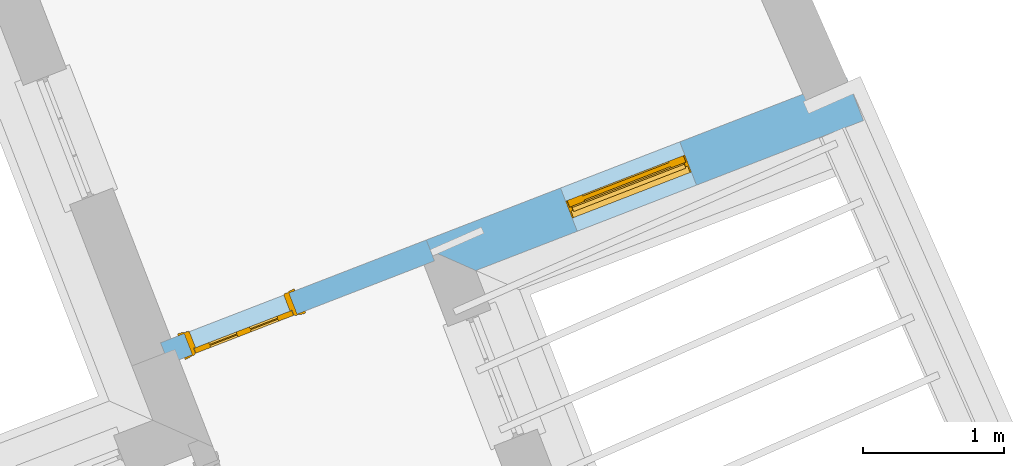
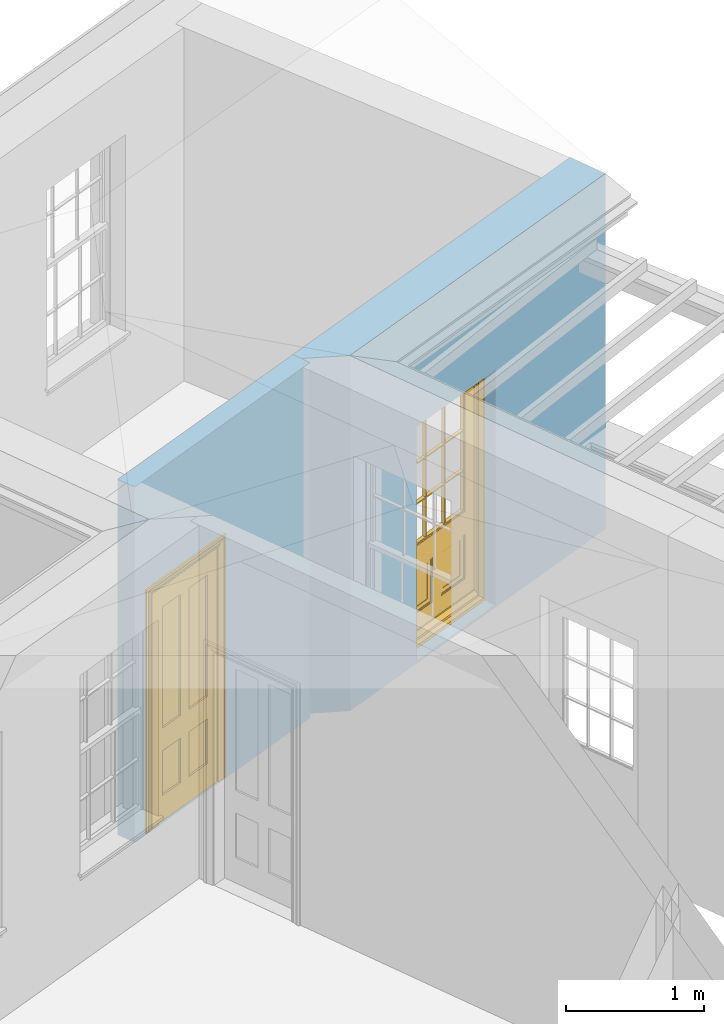
# One storey, part 8 of 11: 2 doors, 2 openings, plus 2 elements that do not belong to this part.
"""IFC2X3 building model written with IfcOpenShell, lengths in metres."""

from ifc_helpers import new_model, si_unit, frame, origin, place, context, subcontext, project, spatial, polyline, outline, extrude, faceted_brep, material, layer, layer_set, layer_usage, element, fill, save


model = new_model("IFC2X3")

# Units and contexts
model_context = context("Model", 3, world=origin())
body_context = subcontext(model_context, "Body", "Model", "MODEL_VIEW")
ifc_project = project(units=[si_unit("PLANEANGLEUNIT", "RADIAN"), si_unit("MASSUNIT", "GRAM", prefix="KILO"), si_unit("FORCEUNIT", "NEWTON", prefix="KILO"), si_unit("LENGTHUNIT", "METRE")], contexts=[model_context])

# Site, building, storey
site_placement = place(None, origin())
site = spatial("IfcSite", under=ifc_project, at=site_placement, CompositionType="ELEMENT")
building_placement = place(None, origin())
building = spatial("IfcBuilding", under=site, at=building_placement, Name="Building plot-5", CompositionType="ELEMENT")
storey_placement = place(None, frame((0.0, 0.0, 7.6)))
storey = spatial("IfcBuildingStorey", under=building, at=storey_placement, Name="Floor 1", CompositionType="ELEMENT", Elevation=7.6)

# Wall, opening, door
ifc_material_1 = material(Name="Masonry")
ifc_layer_1 = layer(ifc_material_1, 0.33, ventilated=False)
ifc_layer_set_1 = layer_set([ifc_layer_1], Name="My Wall")
ifc_layer_usage_1 = layer_usage(ifc_layer_set_1, "AXIS2", "NEGATIVE", 0.08)
wall_1_placement = place(storey_placement, origin())
wall_1 = element("IfcWallStandardCase", 1, at=wall_1_placement, inside=storey, material=ifc_layer_usage_1, Name="exterior", context=body_context, shape_type="SweptSolid", body=[
    extrude(outline(polyline([(61.8338428959176, 59.3683674178337), (62.2606962551514, 59.1796978397062), (65.0186735128031, 60.2469293132381), (64.8995816222499, 60.5546907819187), (61.8338428959176, 59.3683674178337)])), origin(), (0.0, 0.0, 1.0), 3.15),
])
opening_1_placement = place(storey_placement, frame((0.0, 0.0, 0.0199999999999996)))
opening_1 = element("IfcOpeningElement", 2, at=opening_1_placement, cuts=wall_1, Name="Opening", ObjectType="Opening", context=body_context, shape_type="SweptSolid", body=[
    extrude(outline(polyline([(62.9821944736141, 59.4588899921085), (63.8308700387637, 59.7872949024218), (63.7117781482106, 60.0950563711025), (62.8631025830609, 59.7666514607892), (62.9821944736141, 59.4588899921085)])), origin(), (0.0, 0.0, 1.0), 2.08),
])
door_1_placement = place(storey_placement, frame((62.8919733444071, 59.6920426198969, 0.0199999999999996), z_axis=(0.0, 0.0, 1.0), x_axis=(0.848675565149669, 0.328404910313296, 0.0)))
door_1 = element("IfcDoor", 3, at=door_1_placement, inside=storey, Name="bedroom outside door", OverallHeight=2.08, OverallWidth=0.91, context=body_context, shape_type="Brep", held_by="IfcProductRepresentation", body=[
    faceted_brep([(0.545, -0.055, 0.265), (0.745, -0.055, 0.265), (0.745, -0.05, 0.265), (0.545, -0.05, 0.265), (0.745, -0.05, 0.58), (0.545, -0.05, 0.58), (0.545, -0.055, 0.58), (0.515, -0.06, 0.235), (0.775, -0.06, 0.235), (0.745, -0.055, 0.58), (0.515, -0.06, 0.61), (0.515, -0.065, 0.235), (0.775, -0.065, 0.235), (0.775, -0.06, 0.61), (0.515, -0.065, 0.61), (0.785, -0.065, 0.225), (0.505, -0.065, 0.225), (0.775, -0.065, 0.61), (0.505, -0.065, 0.62), (0.785, -0.065, 0.62), (0.505, -0.07, 0.225), (0.785, -0.07, 0.225), (0.505, -0.07, 0.62), (0.785, -0.07, 0.62), (0.883, -0.07, 0.075), (0.898, -0.07, 0.075), (0.405, -0.07, 0.62), (0.405, -0.07, 0.225), (0.027, -0.07, 0.075), (0.785, -0.07, 0.82), (0.125, -0.07, 0.82), (0.405, -0.065, 0.62), (0.405, -0.065, 0.225), (0.898, -0.07, 2.068), (0.027, -0.08, 0.075), (0.883, -0.08, 0.075), (0.125, -0.07, 0.225), (0.012, -0.07, 0.075), (0.785, -0.06, 0.82), (0.125, -0.06, 0.82), (0.125, -0.07, 0.62), (0.125, -0.065, 0.62), (0.395, -0.065, 0.61), (0.395, -0.065, 0.235), (0.125, -0.065, 0.225), (0.785, -0.07, 1.895), (0.027, -0.11, 0.045), (0.883, -0.11, 0.045), (0.558333, -0.06, 0.83), (0.351667, -0.06, 0.83), (0.125, -0.07, 1.895), (0.125, -0.06, 1.895), (0.785, -0.06, 1.895), (0.012, -0.07, 2.068), (0.135, -0.065, 0.61), (0.395, -0.06, 0.61), (0.395, -0.06, 0.235), (0.135, -0.065, 0.235), (0.027, -0.11, 0.027), (0.883, -0.11, 0.027), (0.568333, -0.06, 0.83), (0.558333, -0.03, 0.83), (0.351667, -0.03, 0.83), (0.341667, -0.06, 0.83), (0.135, -0.06, 1.185), (0.135, -0.06, 1.53), (0.775, -0.06, 1.53), (0.775, -0.06, 1.185), (0.135, -0.06, 0.61), (0.365, -0.055, 0.58), (0.365, -0.055, 0.265), (0.135, -0.06, 0.235), (0.568333, -0.06, 1.175), (0.558333, -0.06, 1.175), (0.775, -0.06, 0.83), (0.558333, -0.03, 1.175), (0.785, -0.03, 0.82), (0.125, -0.03, 0.82), (0.351667, -0.03, 1.175), (0.351667, -0.06, 1.175), (0.341667, -0.06, 1.175), (0.135, -0.06, 0.83), (0.135, -0.06, 1.175), (0.135, -0.03, 1.185), (0.135, -0.03, 1.53), (0.135, -0.06, 1.54), (0.351667, -0.06, 1.885), (0.558333, -0.06, 1.885), (0.775, -0.03, 1.53), (0.775, -0.03, 1.185), (0.775, -0.06, 1.175), (0.775, -0.06, 1.54), (0.165, -0.055, 0.58), (0.365, -0.05, 0.58), (0.365, -0.05, 0.265), (0.165, -0.055, 0.265), (0.568333, -0.03, 0.83), (0.568333, -0.03, 1.175), (0.568333, -0.06, 1.185), (0.558333, -0.06, 1.185), (0.775, -0.03, 0.83), (0.785, -0.02, 0.82), (0.125, -0.02, 0.82), (0.341667, -0.03, 0.83), (0.341667, -0.03, 1.175), (0.351667, -0.06, 1.185), (0.341667, -0.06, 1.185), (0.135, -0.03, 0.83), (0.341667, -0.03, 1.185), (0.125, -0.03, 1.895), (0.341667, -0.03, 1.53), (0.341667, -0.06, 1.53), (0.135, -0.06, 1.885), (0.341667, -0.06, 1.54), (0.341667, -0.06, 1.885), (0.558333, -0.03, 1.885), (0.351667, -0.03, 1.885), (0.568333, -0.06, 1.885), (0.785, -0.03, 1.895), (0.568333, -0.03, 1.185), (0.568333, -0.06, 1.53), (0.568333, -0.03, 1.53), (0.568333, -0.06, 1.54), (0.775, -0.06, 1.885), (0.165, -0.05, 0.58), (0.165, -0.05, 0.265), (0.775, -0.03, 1.175), (0.558333, -0.06, 1.53), (0.351667, -0.03, 1.185), (0.558333, -0.03, 1.185), (0.505, -0.02, 0.62), (0.405, -0.02, 0.62), (0.125, -0.02, 1.895), (0.785, -0.02, 1.895), (0.351667, -0.06, 1.53), (0.135, -0.03, 1.175), (0.135, -0.03, 1.54), (0.341667, -0.03, 1.54), (0.135, -0.03, 1.885), (0.351667, -0.06, 1.54), (0.558333, -0.03, 1.54), (0.558333, -0.06, 1.54), (0.351667, -0.03, 1.54), (0.775, -0.03, 1.54), (0.568333, -0.03, 1.54), (0.775, -0.03, 1.885), (0.558333, -0.03, 1.53), (0.405, -0.02, 0.225), (0.505, -0.02, 0.225), (0.125, -0.02, 0.62), (0.785, -0.02, 0.62), (0.012, -0.02, 2.068), (0.898, -0.02, 2.068), (0.351667, -0.03, 1.53), (0.341667, -0.03, 1.885), (0.568333, -0.03, 1.885), (0.405, -0.025, 0.225), (0.405, -0.025, 0.62), (0.505, -0.025, 0.62), (0.505, -0.025, 0.225), (0.898, -0.02, 0.027), (0.012, -0.02, 0.027), (0.125, -0.025, 0.62), (0.785, -0.025, 0.62), (0.395, -0.025, 0.235), (0.395, -0.025, 0.61), (0.125, -0.02, 0.225), (0.125, -0.025, 0.225), (0.515, -0.025, 0.61), (0.515, -0.025, 0.235), (0.785, -0.02, 0.225), (0.785, -0.025, 0.225), (0.135, -0.025, 0.61), (0.775, -0.025, 0.61), (0.135, -0.025, 0.235), (0.395, -0.03, 0.235), (0.395, -0.03, 0.61), (0.515, -0.03, 0.61), (0.515, -0.03, 0.235), (0.775, -0.025, 0.235), (0.135, -0.03, 0.61), (0.775, -0.03, 0.61), (0.135, -0.03, 0.235), (0.365, -0.035, 0.265), (0.365, -0.035, 0.58), (0.545, -0.035, 0.58), (0.545, -0.035, 0.265), (0.775, -0.03, 0.235), (0.165, -0.035, 0.58), (0.745, -0.035, 0.58), (0.165, -0.035, 0.265), (0.365, -0.04, 0.58), (0.365, -0.04, 0.265), (0.545, -0.04, 0.58), (0.545, -0.04, 0.265), (0.745, -0.035, 0.265), (0.165, -0.04, 0.58), (0.745, -0.04, 0.58), (0.165, -0.04, 0.265), (0.745, -0.04, 0.265), (0.885, -0.072, 0.025), (0.025, -0.072, 0.025), (0.025, -0.1, 0.025), (0.885, -0.1, 0.025), (0.9, -0.02, 0.025), (0.01, -0.02, 0.025), (0.9, -0.072, 0.025), (0.91, -0.02, 0.0), (0.0, -0.02, 0.0), (0.01, -0.072, 0.025), (0.9, -0.072, 2.07), (0.9, -0.02, 2.07), (0.885, -0.072, 2.055), (0.91, -0.02, 2.08), (0.01, -0.02, 2.07), (0.0, -0.02, 2.08), (0.01, -0.072, 2.07), (0.025, -0.072, 2.055), (0.0, -0.15, 2.08), (0.91, -0.15, 2.08), (0.01, -0.15, 2.07), (0.9, -0.15, 2.07), (0.01, -0.1, 2.07), (0.9, -0.1, 2.07), (0.0, -0.15, 0.0), (0.91, -0.15, 0.0), (0.01, -0.15, 0.025), (0.9, -0.15, 0.025), (0.01, -0.1, 0.025), (0.025, -0.1, 2.055), (0.9, -0.1, 0.025), (0.885, -0.1, 2.055), (0.898, -0.07, 0.027), (0.012, -0.07, 0.027), (0.883, -0.07, 0.027), (0.027, -0.07, 0.027)], [[[0, 1, 2, 3]], [[2, 4, 5, 3]], [[0, 3, 5, 6]], [[1, 0, 7, 8]], [[9, 4, 2, 1]], [[9, 6, 5, 4]], [[0, 6, 10, 7]], [[8, 7, 11, 12]], [[8, 13, 9, 1]], [[13, 10, 6, 9]], [[7, 10, 14, 11]], [[15, 12, 11, 16]], [[12, 17, 13, 8]], [[17, 14, 10, 13]], [[18, 16, 11, 14]], [[15, 19, 17, 12]], [[15, 16, 20, 21]], [[14, 17, 19, 18]], [[16, 18, 22, 20]], [[21, 23, 19, 15]], [[24, 25, 21, 20]], [[23, 22, 18, 19]], [[20, 22, 26, 27]], [[23, 21, 25]], [[28, 24, 20, 27]], [[22, 23, 29]], [[29, 30, 26, 22]], [[27, 26, 31, 32]], [[23, 25, 33, 29]], [[34, 35, 24, 28]], [[28, 27, 36, 37]], [[38, 39, 30, 29]], [[26, 30, 40]], [[26, 40, 41, 31]], [[42, 43, 32, 31]], [[32, 44, 36, 27]], [[33, 45, 29]], [[46, 47, 35, 34]], [[36, 40, 37]], [[39, 38, 48, 49]], [[50, 30, 39, 51]], [[29, 45, 52, 38]], [[53, 37, 40, 30]], [[44, 41, 40, 36]], [[31, 41, 54, 42]], [[43, 42, 55, 56]], [[57, 44, 32, 43]], [[50, 45, 33, 53]], [[47, 46, 58, 59]], [[60, 48, 38]], [[49, 48, 61, 62]], [[49, 63, 39]], [[50, 53, 30]], [[51, 39, 64, 65]], [[45, 50, 51, 52]], [[66, 67, 38, 52]], [[57, 54, 41, 44]], [[42, 54, 68, 55]], [[56, 55, 69, 70]], [[56, 71, 57, 43]], [[60, 72, 73, 48]], [[60, 38, 74]], [[48, 73, 75, 61]], [[76, 77, 62, 61]], [[62, 78, 79, 49]], [[49, 79, 80, 63]], [[63, 81, 39]], [[82, 64, 39]], [[65, 64, 83, 84]], [[85, 51, 65]], [[52, 51, 86, 87]], [[88, 89, 67, 66]], [[90, 38, 67]], [[91, 66, 52]], [[71, 68, 54, 57]], [[55, 68, 92, 69]], [[69, 93, 94, 70]], [[70, 95, 71, 56]], [[96, 97, 72, 60]], [[73, 72, 98, 99]], [[74, 38, 90]], [[100, 96, 60, 74]], [[75, 73, 79, 78]], [[61, 75, 97, 96]], [[101, 102, 77, 76]], [[77, 103, 62]], [[96, 76, 61]], [[103, 104, 78, 62]], [[80, 79, 105, 106]], [[63, 80, 104, 103]], [[81, 63, 103, 107]], [[81, 82, 39]], [[106, 64, 82, 80]], [[106, 108, 83, 64]], [[84, 83, 77, 109]], [[110, 111, 65, 84]], [[112, 51, 85]], [[113, 85, 65, 111]], [[114, 86, 51]], [[115, 87, 86, 116]], [[117, 52, 87]], [[118, 76, 89, 88]], [[119, 98, 67, 89]], [[120, 121, 88, 66]], [[67, 98, 72, 90]], [[91, 122, 120, 66]], [[91, 52, 123]], [[95, 92, 68, 71]], [[69, 92, 124, 93]], [[94, 93, 124, 125]], [[94, 125, 95, 70]], [[72, 97, 126, 90]], [[127, 99, 98, 120]], [[99, 105, 79, 73]], [[74, 90, 126, 100]], [[96, 100, 76]], [[128, 129, 75, 78]], [[97, 75, 129, 119]], [[130, 131, 102, 101]], [[109, 77, 102, 132]], [[133, 101, 76, 118]], [[77, 107, 103]], [[78, 104, 108, 128]], [[111, 106, 105, 134]], [[104, 80, 82, 135]], [[107, 135, 82, 81]], [[110, 108, 106, 111]], [[104, 135, 83, 108]], [[83, 135, 77]], [[136, 84, 109]], [[110, 84, 136, 137]], [[114, 51, 112]], [[85, 136, 138, 112]], [[113, 137, 136, 85]], [[111, 134, 139, 113]], [[86, 114, 113, 139]], [[140, 141, 87, 115]], [[139, 142, 116, 86]], [[109, 118, 115, 116]], [[117, 123, 52]], [[117, 87, 141, 122]], [[126, 89, 76]], [[143, 118, 88]], [[120, 98, 119, 121]], [[119, 89, 126, 97]], [[144, 143, 88, 121]], [[144, 122, 91, 143]], [[127, 120, 122, 141]], [[143, 91, 123, 145]], [[124, 92, 95, 125]], [[146, 129, 99, 127]], [[99, 129, 128, 105]], [[100, 126, 76]], [[121, 119, 129, 146]], [[147, 131, 130, 148]], [[131, 149, 102]], [[130, 101, 150]], [[102, 151, 132]], [[118, 109, 132, 133]], [[101, 133, 152]], [[107, 77, 135]], [[153, 128, 108, 110]], [[134, 105, 128, 153]], [[109, 138, 136]], [[153, 110, 137, 142]], [[154, 114, 112, 138]], [[137, 113, 114, 154]], [[141, 139, 134, 127]], [[141, 140, 142, 139]], [[144, 140, 115, 155]], [[142, 137, 154, 116]], [[155, 115, 118]], [[116, 154, 109]], [[117, 155, 145, 123]], [[122, 144, 155, 117]], [[143, 145, 118]], [[121, 146, 140, 144]], [[146, 127, 134, 153]], [[156, 157, 131, 147]], [[148, 130, 158, 159]], [[148, 160, 161, 147]], [[157, 162, 149, 131]], [[161, 151, 102, 149]], [[101, 152, 160, 150]], [[163, 158, 130, 150]], [[151, 152, 133, 132]], [[154, 138, 109]], [[142, 140, 146, 153]], [[145, 155, 118]], [[157, 156, 164, 165]], [[147, 166, 167, 156]], [[168, 169, 159, 158]], [[170, 148, 159, 171]], [[148, 170, 160]], [[166, 147, 161]], [[172, 162, 157, 165]], [[166, 149, 162, 167]], [[166, 161, 149]], [[150, 160, 170]], [[163, 173, 168, 158]], [[171, 163, 150, 170]], [[174, 164, 156, 167]], [[175, 176, 165, 164]], [[169, 168, 177, 178]], [[171, 159, 169, 179]], [[167, 162, 172, 174]], [[176, 180, 172, 165]], [[179, 173, 163, 171]], [[181, 177, 168, 173]], [[164, 174, 182, 175]], [[183, 184, 176, 175]], [[178, 177, 185, 186]], [[179, 169, 178, 187]], [[174, 172, 180, 182]], [[184, 188, 180, 176]], [[187, 181, 173, 179]], [[189, 185, 177, 181]], [[175, 182, 190, 183]], [[191, 184, 183, 192]], [[185, 193, 194, 186]], [[187, 178, 186, 195]], [[182, 180, 188, 190]], [[191, 196, 188, 184]], [[195, 189, 181, 187]], [[197, 193, 185, 189]], [[183, 190, 198, 192]], [[198, 196, 191, 192]], [[194, 193, 197, 199]], [[195, 186, 194, 199]], [[188, 196, 198, 190]], [[197, 189, 195, 199]], [[200, 201, 202, 203]], [[201, 200, 204, 205]], [[206, 204, 200]], [[204, 207, 208, 205]], [[209, 201, 205]], [[210, 211, 204, 206]], [[206, 200, 212, 210]], [[211, 213, 207, 204]], [[214, 205, 208, 215]], [[216, 217, 201, 209]], [[205, 214, 216, 209]], [[216, 214, 211, 210]], [[210, 212, 217, 216]], [[214, 215, 213, 211]], [[218, 219, 213, 215]], [[219, 218, 220, 221]], [[221, 220, 222, 223]], [[215, 208, 224, 218]], [[225, 224, 208, 207]], [[224, 226, 220, 218]], [[224, 225, 227, 226]], [[219, 225, 207, 213]], [[228, 222, 220, 226]], [[219, 221, 227, 225]], [[226, 227, 203, 202]], [[202, 229, 222, 228]], [[228, 226, 202]], [[227, 221, 223, 230]], [[230, 203, 227]], [[217, 229, 202, 201]], [[231, 223, 222, 229]], [[230, 223, 231, 203]], [[231, 229, 217, 212]], [[212, 200, 203, 231]], [[33, 152, 151, 53]], [[25, 160, 152, 33]], [[161, 37, 53, 151]], [[232, 160, 25]], [[161, 233, 37]], [[160, 232, 234]], [[24, 234, 232, 25]], [[233, 161, 235]], [[37, 233, 235, 28]], [[161, 160, 234, 235]], [[35, 47, 234, 24]], [[28, 235, 46, 34]], [[58, 235, 234, 59]], [[59, 234, 47]], [[58, 46, 235]]]),
])
fill(opening_1, door_1)

ifc_material_2 = material(Name="Masonry")
ifc_layer_2 = layer(ifc_material_2, 0.16, ventilated=False)
ifc_layer_set_2 = layer_set([ifc_layer_2], Name="My Wall")
ifc_layer_usage_2 = layer_usage(ifc_layer_set_2, "AXIS2", "NEGATIVE", 0.08)
wall_2_placement = place(storey_placement, origin())
wall_2 = element("IfcWallStandardCase", 4, at=wall_2_placement, inside=storey, material=ifc_layer_usage_2, Name="interior", context=body_context, shape_type="SweptSolid", body=[
    extrude(outline(polyline([(61.9661932595023, 59.2480204973953), (61.9084517368099, 59.3972381791799), (60.0171848108104, 58.6653903792473), (60.0749263335028, 58.5161726974627), (61.9661932595023, 59.2480204973953)])), origin(), (0.0, 0.0, 1.0), 3.15),
])
opening_2_placement = place(storey_placement, frame((0.0, 0.0, 0.0199999999999996)))
opening_2 = element("IfcOpeningElement", 5, at=opening_2_placement, cuts=wall_2, Name="Opening", ObjectType="Opening", context=body_context, shape_type="SweptSolid", body=[
    extrude(outline(polyline([(60.9311431117408, 59.0190572057385), (60.185054702818, 58.7303495922763), (60.2427962255104, 58.5811319104917), (60.9888846344332, 58.8698395239539), (60.9311431117408, 59.0190572057385)])), origin(), (0.0, 0.0, 1.0), 2.1),
])
door_2_placement = place(storey_placement, frame((60.960013873087, 58.9444483648462, 0.0199999999999996), z_axis=(0.0, 0.0, 1.0), x_axis=(-0.746088408922795, -0.288707613462229, 0.0)))
door_2 = element("IfcDoor", 6, at=door_2_placement, inside=storey, Name="bedroom inside door", OverallHeight=2.1, OverallWidth=0.8, context=body_context, shape_type="Brep", held_by="IfcProductRepresentation", body=[
    faceted_brep([(0.773, 0.08, 1.895), (0.66, 0.08, 1.895), (0.66, 0.08, 2.073), (0.773, 0.08, 2.073), (0.773, 0.08, 0.82), (0.66, 0.08, 0.82), (0.45, 0.08, 1.895), (0.45, 0.08, 2.073), (0.773, 0.08, 0.62), (0.66, 0.08, 0.62), (0.66, 0.065, 0.82), (0.66, 0.065, 1.895), (0.45, 0.065, 1.895), (0.35, 0.08, 1.895), (0.35, 0.08, 2.073), (0.773, 0.08, 0.225), (0.66, 0.08, 0.225), (0.45, 0.08, 0.62), (0.45, 0.08, 0.82), (0.45, 0.065, 0.82), (0.35, 0.08, 0.82), (0.14, 0.08, 2.073), (0.14, 0.08, 1.895), (0.773, 0.08, 0.0), (0.66, 0.08, 0.0), (0.66, 0.065, 0.225), (0.66, 0.065, 0.62), (0.45, 0.065, 0.62), (0.35, 0.08, 0.62), (0.35, 0.065, 0.82), (0.35, 0.065, 1.895), (0.14, 0.065, 1.895), (0.027, 0.08, 2.073), (0.027, 0.08, 1.895), (0.773, 0.042, 0.0), (0.66, 0.042, 0.0), (0.45, 0.08, 0.0), (0.45, 0.08, 0.225), (0.45, 0.065, 0.225), (0.35, 0.08, 0.225), (0.14, 0.08, 0.82), (0.14, 0.08, 0.62), (0.14, 0.065, 0.82), (0.027, 0.08, 0.82), (0.773, 0.042, 0.225), (0.66, 0.042, 0.225), (0.45, 0.042, 0.0), (0.35, 0.08, 0.0), (0.35, 0.065, 0.225), (0.35, 0.065, 0.62), (0.14, 0.065, 0.62), (0.027, 0.08, 0.62), (0.773, 0.042, 0.62), (0.66, 0.042, 0.62), (0.45, 0.042, 0.225), (0.35, 0.042, 0.0), (0.14, 0.08, 0.225), (0.14, 0.08, 0.0), (0.14, 0.065, 0.225), (0.027, 0.08, 0.225), (0.773, 0.042, 0.82), (0.66, 0.042, 0.82), (0.66, 0.057, 0.62), (0.66, 0.057, 0.225), (0.45, 0.057, 0.225), (0.35, 0.042, 0.225), (0.14, 0.042, 0.0), (0.027, 0.08, 0.0), (0.773, 0.042, 1.895), (0.66, 0.042, 1.895), (0.45, 0.042, 0.62), (0.45, 0.042, 0.82), (0.45, 0.057, 0.62), (0.35, 0.042, 0.62), (0.14, 0.042, 0.225), (0.027, 0.042, 0.0), (0.773, 0.042, 2.073), (0.66, 0.042, 2.073), (0.66, 0.057, 1.895), (0.66, 0.057, 0.82), (0.45, 0.057, 0.82), (0.35, 0.042, 0.82), (0.35, 0.057, 0.62), (0.35, 0.057, 0.225), (0.14, 0.057, 0.225), (0.027, 0.042, 0.225), (0.45, 0.042, 1.895), (0.45, 0.042, 2.073), (0.45, 0.057, 1.895), (0.35, 0.042, 1.895), (0.14, 0.042, 0.82), (0.14, 0.042, 0.62), (0.14, 0.057, 0.62), (0.027, 0.042, 0.62), (0.35, 0.042, 2.073), (0.35, 0.057, 1.895), (0.35, 0.057, 0.82), (0.14, 0.057, 0.82), (0.027, 0.042, 0.82), (0.14, 0.042, 2.073), (0.14, 0.042, 1.895), (0.14, 0.057, 1.895), (0.027, 0.042, 1.895), (0.027, 0.042, 2.073), (0.02, 0.085, 0.0), (0.005, 0.09, 0.0), (0.005, 0.09, 2.095), (0.02, 0.085, 2.08), (0.02, 0.08, 0.0), (0.0, 0.085, 0.0), (0.0, 0.085, 2.1), (0.795, 0.09, 2.095), (0.78, 0.085, 2.08), (0.02, 0.08, 2.08), (0.0, 0.08, 0.0), (-0.032, 0.095, 0.0), (-0.032, 0.095, 2.132), (0.8, 0.085, 2.1), (0.795, 0.09, 0.0), (0.78, 0.085, 0.0), (0.78, 0.08, 2.08), (0.04, 0.04, 0.0), (0.025, 0.04, 0.0), (0.025, 0.04, 2.075), (0.04, 0.04, 2.06), (-0.04, 0.09, 0.0), (-0.04, 0.09, 2.14), (0.832, 0.095, 2.132), (0.8, 0.085, 0.0), (0.78, 0.08, 0.0), (0.8, 0.08, 0.0), (0.86, 0.08, 0.0), (0.86, 0.08, 2.16), (0.8, 0.08, 2.1), (-0.06, 0.08, 2.16), (0.0, 0.08, 2.1), (-0.06, 0.08, 0.0), (-0.04, 0.095, 0.0), (-0.04, 0.095, 2.14), (0.84, 0.09, 2.14), (0.832, 0.095, 0.0), (0.84, 0.09, 0.0), (0.86, 0.095, 0.0), (0.86, 0.095, 2.16), (-0.06, 0.095, 2.16), (-0.06, 0.095, 0.0), (0.84, 0.095, 0.0), (0.84, 0.095, 2.14), (-0.025, -0.095, 0.0), (-0.025, -0.09, 0.0), (-0.025, -0.09, 2.125), (-0.025, -0.095, 2.125), (-0.017, -0.095, 0.0), (-0.017, -0.095, 2.117), (0.825, -0.09, 2.125), (0.825, -0.095, 2.125), (0.825, -0.095, 0.0), (0.845, -0.095, 0.0), (-0.045, -0.095, 2.145), (-0.045, -0.095, 0.0), (0.845, -0.095, 2.145), (0.015, -0.085, 0.0), (0.015, -0.085, 2.085), (0.817, -0.095, 2.117), (0.825, -0.09, 0.0), (0.845, -0.08, 0.0), (0.845, -0.08, 2.145), (-0.045, -0.08, 2.145), (-0.045, -0.08, 0.0), (0.02, -0.09, 0.0), (0.02, -0.09, 2.08), (0.785, -0.085, 2.085), (0.817, -0.095, 0.0), (0.8, -0.08, 0.0), (0.8, -0.08, 2.1), (0.0, -0.08, 2.1), (0.0, -0.08, 0.0), (0.035, -0.085, 0.0), (0.035, -0.085, 2.065), (0.78, -0.09, 2.08), (0.785, -0.085, 0.0), (0.775, 0.04, 2.075), (0.76, 0.04, 2.06), (0.035, -0.08, 2.065), (0.035, -0.08, 0.0), (0.765, -0.085, 2.065), (0.78, -0.09, 0.0), (0.765, -0.08, 0.0), (0.765, -0.08, 2.065), (0.765, -0.085, 0.0), (0.04, -0.08, 2.06), (0.04, -0.08, 0.0), (0.76, -0.08, 2.06), (0.76, -0.08, 0.0), (0.76, 0.04, 0.0), (0.775, 0.04, 0.0), (0.025, 0.08, 0.0), (0.025, 0.08, 2.075), (0.775, 0.08, 0.0), (0.775, 0.08, 2.075)], [[[0, 1, 2, 3]], [[1, 0, 4, 5]], [[1, 6, 7, 2]], [[8, 9, 5, 4]], [[1, 5, 10, 11]], [[6, 1, 11, 12]], [[6, 13, 14, 7]], [[15, 16, 9, 8]], [[9, 17, 18, 5]], [[5, 18, 19, 10]], [[10, 19, 12, 11]], [[18, 6, 12, 19]], [[18, 20, 13, 6]], [[21, 14, 13, 22]], [[23, 24, 16, 15]], [[9, 16, 25, 26]], [[17, 9, 26, 27]], [[17, 28, 20, 18]], [[13, 20, 29, 30]], [[22, 13, 30, 31]], [[32, 21, 22, 33]], [[34, 35, 24, 23]], [[24, 36, 37, 16]], [[16, 37, 38, 25]], [[25, 38, 27, 26]], [[37, 17, 27, 38]], [[37, 39, 28, 17]], [[40, 20, 28, 41]], [[20, 40, 42, 29]], [[31, 30, 29, 42]], [[40, 22, 31, 42]], [[33, 22, 40, 43]], [[35, 34, 44, 45]], [[35, 46, 36, 24]], [[36, 47, 39, 37]], [[28, 39, 48, 49]], [[41, 28, 49, 50]], [[43, 40, 41, 51]], [[45, 44, 52, 53]], [[46, 35, 45, 54]], [[46, 55, 47, 36]], [[56, 39, 47, 57]], [[39, 56, 58, 48]], [[50, 49, 48, 58]], [[56, 41, 50, 58]], [[51, 41, 56, 59]], [[53, 52, 60, 61]], [[45, 53, 62, 63]], [[54, 45, 63, 64]], [[55, 46, 54, 65]], [[55, 66, 57, 47]], [[59, 56, 57, 67]], [[61, 60, 68, 69]], [[70, 53, 61, 71]], [[53, 70, 72, 62]], [[72, 64, 63, 62]], [[70, 54, 64, 72]], [[65, 54, 70, 73]], [[65, 74, 66, 55]], [[67, 57, 66, 75]], [[69, 68, 76, 77]], [[61, 69, 78, 79]], [[71, 61, 79, 80]], [[73, 70, 71, 81]], [[65, 73, 82, 83]], [[74, 65, 83, 84]], [[74, 85, 75, 66]], [[86, 69, 77, 87]], [[69, 86, 88, 78]], [[88, 80, 79, 78]], [[86, 71, 80, 88]], [[81, 71, 86, 89]], [[73, 81, 90, 91]], [[73, 91, 92, 82]], [[83, 82, 92, 84]], [[91, 74, 84, 92]], [[91, 93, 85, 74]], [[89, 86, 87, 94]], [[81, 89, 95, 96]], [[90, 81, 96, 97]], [[90, 98, 93, 91]], [[94, 99, 100, 89]], [[89, 100, 101, 95]], [[101, 97, 96, 95]], [[100, 90, 97, 101]], [[100, 102, 98, 90]], [[99, 103, 102, 100]], [[32, 103, 99, 21]], [[102, 103, 32, 33]], [[98, 102, 33, 43]], [[21, 99, 94, 14]], [[94, 87, 7, 14]], [[7, 87, 77, 2]], [[76, 3, 2, 77]], [[43, 51, 93, 98]], [[51, 59, 85, 93]], [[67, 75, 85, 59]], [[34, 23, 15, 44]], [[44, 15, 8, 52]], [[52, 8, 4, 60]], [[0, 68, 60, 4]], [[0, 3, 76, 68]], [[104, 105, 106, 107]], [[104, 108, 109, 105]], [[105, 109, 110, 106]], [[107, 106, 111, 112]], [[107, 113, 108, 104]], [[114, 109, 108]], [[109, 115, 116, 110]], [[106, 110, 117, 111]], [[112, 111, 118, 119]], [[113, 107, 112, 120]], [[121, 122, 123, 124]], [[115, 109, 114, 125]], [[115, 125, 126, 116]], [[110, 116, 127, 117]], [[111, 117, 128, 118]], [[118, 128, 129, 119]], [[120, 112, 119, 129]], [[130, 129, 128]], [[130, 131, 132, 133]], [[133, 132, 134, 135]], [[135, 134, 136, 114]], [[136, 125, 114]], [[125, 137, 138, 126]], [[116, 126, 139, 127]], [[117, 127, 140, 128]], [[141, 130, 128, 140]], [[131, 130, 141]], [[131, 142, 143, 132]], [[132, 143, 144, 134]], [[134, 144, 145, 136]], [[137, 125, 136, 145]], [[143, 142, 146]], [[143, 146, 147]], [[137, 145, 144]], [[143, 147, 138]], [[138, 137, 144]], [[143, 138, 144]], [[126, 138, 147, 139]], [[127, 139, 141, 140]], [[142, 131, 141, 146]], [[139, 147, 146, 141]], [[148, 149, 150, 151]], [[149, 152, 153, 150]], [[151, 150, 154, 155]], [[155, 156, 157]], [[158, 159, 148]], [[158, 148, 151]], [[155, 157, 160]], [[158, 151, 155]], [[155, 160, 158]], [[152, 161, 162, 153]], [[150, 153, 163, 154]], [[155, 154, 164, 156]], [[156, 164, 165, 157]], [[157, 165, 166, 160]], [[160, 166, 167, 158]], [[158, 167, 168, 159]], [[161, 169, 170, 162]], [[153, 162, 171, 163]], [[154, 163, 172, 164]], [[165, 164, 173]], [[165, 173, 174, 166]], [[166, 174, 175, 167]], [[167, 175, 176, 168]], [[169, 177, 178, 170]], [[162, 170, 179, 171]], [[163, 171, 180, 172]], [[172, 180, 173, 164]], [[124, 123, 181, 182]], [[183, 178, 177, 184]], [[170, 178, 185, 179]], [[171, 179, 186, 180]], [[187, 173, 180]], [[185, 188, 187, 189]], [[188, 185, 178, 183]], [[179, 185, 189, 186]], [[189, 187, 180, 186]], [[190, 183, 184, 191]], [[192, 188, 183, 190]], [[191, 184, 122, 121]], [[124, 190, 191, 121]], [[193, 187, 188, 192]], [[182, 192, 190, 124]], [[184, 176, 122]], [[194, 195, 187, 193]], [[192, 182, 194, 193]], [[161, 176, 184]], [[114, 108, 122, 176]], [[173, 187, 195]], [[152, 149, 176, 161]], [[169, 161, 184, 177]], [[196, 122, 108]], [[176, 175, 135, 114]], [[173, 195, 129, 130]], [[176, 149, 168]], [[123, 122, 196, 197]], [[196, 108, 113, 197]], [[175, 174, 133, 135]], [[198, 129, 195]], [[133, 174, 173, 130]], [[159, 168, 149, 148]], [[181, 123, 197, 199]], [[197, 113, 120, 199]], [[199, 120, 129, 198]], [[195, 181, 199, 198]], [[195, 194, 182, 181]]]),
])
fill(opening_2, door_2)

save(model, "model.ifc")
